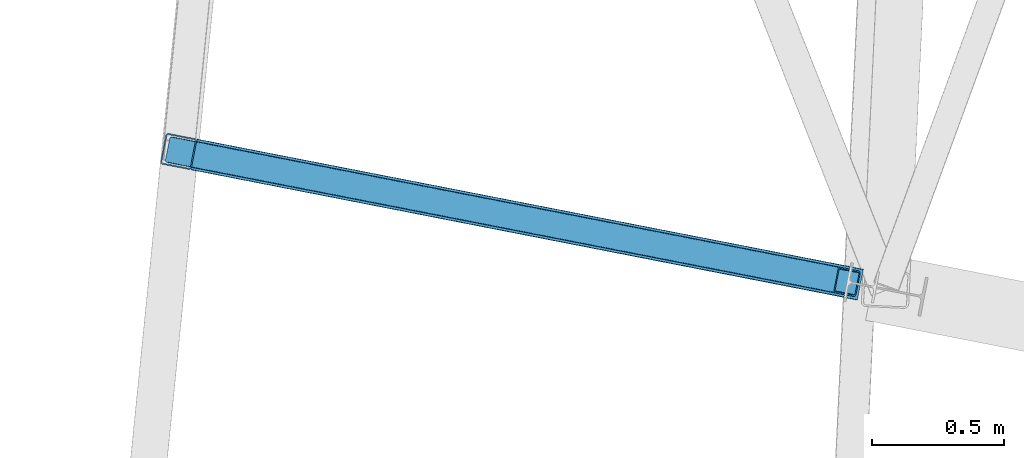
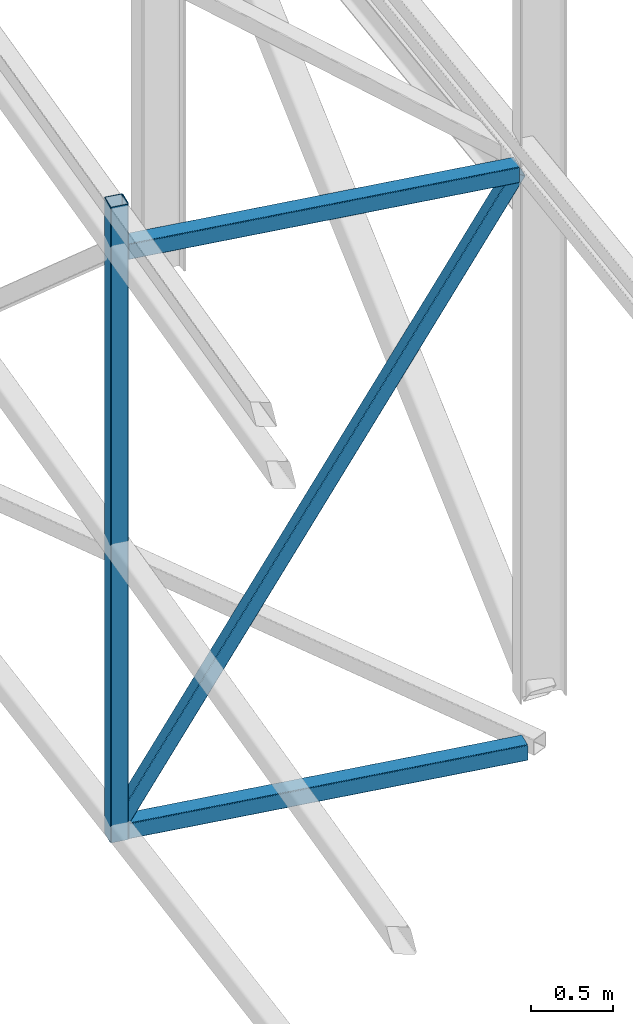
# One storey, part 41 of 215: 3 beams, 1 member, 4 elements without a shape of their own.
"""IFC2X3 building model written with IfcOpenShell, lengths in millimetres."""

import ifcopenshell
import ifcopenshell.guid

model = None  # the IFC model being written
_history = None  # IfcOwnerHistory: only IFC2X3 demands one
_inside = {}  # id of a spatial element -> (the spatial element, [elements in it])
_under = {}  # id of a project, library or spatial element -> (it, [spatial elements below it])
_declared = {}  # id of a project -> (the project, [libraries it declares])
_typed = {}  # id of a type object -> (the type object, [elements of that type])
_made_of = {}  # id of a material, layer set ... -> (it, [elements and type objects made of it])


def new_model(schema):
    """Start an empty IFC model of exactly this schema.

    Asked for "IFC4X3", IfcOpenShell would pick the latest addendum, in which some entities
    have other attributes; the version numbers below select the first issue.
    IFC2X3 requires an IfcOwnerHistory on every rooted entity: one is made here for all.
    """
    global model, _history
    if schema == "IFC4X3":
        model = ifcopenshell.file(schema_version=(4, 3, 0, 0))
    else:
        model = ifcopenshell.file(schema=schema)
    _inside.clear()
    _under.clear()
    _declared.clear()
    _typed.clear()
    _made_of.clear()
    _history = None
    if model.schema == "IFC2X3":
        org = make("IfcOrganization", Name="unknown")
        user = make(
            "IfcPersonAndOrganization",
            ThePerson=make("IfcPerson", FamilyName="unknown"),
            TheOrganization=org,
        )
        app = make(
            "IfcApplication",
            ApplicationDeveloper=org,
            Version="unknown",
            ApplicationFullName="unknown",
            ApplicationIdentifier="unknown",
        )
        _history = make(
            "IfcOwnerHistory",
            OwningUser=user,
            OwningApplication=app,
            ChangeAction="ADDED",
            CreationDate=0,
        )
    return model


def make(cls, **values):
    """One entity of the class cls with the attributes given. An attribute that is None is left unset."""
    return model.create_entity(
        cls, **{name: value for name, value in values.items() if value is not None}
    )


def rooted(cls, **values):
    """An entity with a GlobalId (a new one), such as an element, a storey or a relation."""
    return make(cls, GlobalId=ifcopenshell.guid.new(), OwnerHistory=_history, **values)


def si_unit(unit_type, name, prefix=None):
    """IfcSIUnit, for example si_unit("LENGTHUNIT", "METRE", prefix="MILLI")."""
    return make("IfcSIUnit", UnitType=unit_type, Prefix=prefix, Name=name)


def assignment(units):
    """IfcUnitAssignment: the units of a project."""
    return None if units is None else make("IfcUnitAssignment", Units=units)


def point(xyz):
    """IfcCartesianPoint."""
    return None if xyz is None else make("IfcCartesianPoint", Coordinates=xyz)


def direction(xyz):
    """IfcDirection."""
    return None if xyz is None else make("IfcDirection", DirectionRatios=xyz)


def frame(location, z_axis=None, x_axis=None):
    """IfcAxis2Placement3D, a coordinate frame: its origin and axes. An axis left out is left unset."""
    return make(
        "IfcAxis2Placement3D",
        Location=point(location),
        Axis=direction(z_axis),
        RefDirection=direction(x_axis),
    )


def frame_2d(location, x_axis=None):
    """IfcAxis2Placement2D, a coordinate frame in the plane: its origin and x axis."""
    return make(
        "IfcAxis2Placement2D", Location=point(location), RefDirection=direction(x_axis)
    )


def origin_with_axes():
    """The frame at (0, 0, 0) with the z axis (0, 0, 1) and the x axis (1, 0, 0) written out."""
    return frame((0.0, 0.0, 0.0), z_axis=(0.0, 0.0, 1.0), x_axis=(1.0, 0.0, 0.0))


def origin_2d_with_axis():
    """The frame at (0, 0) in the plane with the x axis (1, 0) written out."""
    return frame_2d((0.0, 0.0), x_axis=(1.0, 0.0))


def place(relative_to, where):
    """IfcLocalPlacement: puts the frame where relative to a parent placement (None: the world)."""
    return make(
        "IfcLocalPlacement", PlacementRelTo=relative_to, RelativePlacement=where
    )


def context(
    kind, dimensions, precision=None, world=None, true_north=None, identifier=None
):
    """IfcGeometricRepresentationContext, for example the 3D "Model" context."""
    return make(
        "IfcGeometricRepresentationContext",
        ContextIdentifier=identifier,
        ContextType=kind,
        CoordinateSpaceDimension=dimensions,
        Precision=precision,
        WorldCoordinateSystem=world,
        TrueNorth=true_north,
    )


def subcontext(parent, identifier, kind, view, scale=None):
    """IfcGeometricRepresentationSubContext, for example "Body" below "Model"."""
    return make(
        "IfcGeometricRepresentationSubContext",
        ContextIdentifier=identifier,
        ContextType=kind,
        ParentContext=parent,
        TargetScale=scale,
        TargetView=view,
    )


def project(units=None, contexts=None):
    """IfcProject with its units and contexts."""
    return rooted(
        "IfcProject",
        Name="project",
        RepresentationContexts=contexts,
        UnitsInContext=assignment(units),
    )


def spatial(cls, under=None, at=None, **own):
    """A site, building, storey or space (cls), placed at a placement, below another one or the project."""
    s = rooted(cls, ObjectPlacement=at, **own)
    if under is not None:
        _under.setdefault(under.id(), (under, []))[1].append(s)
    return s


def profile(cls, at=None, kind="AREA", **sizes):
    """A parametric profile (cls). Its sizes go by their IFC names, for example OverallWidth=200.0."""
    return make(cls, ProfileType=kind, Position=at, **sizes)


def hollow_rectangle(**sizes):
    """IfcRectangleHollowProfileDef."""
    return profile("IfcRectangleHollowProfileDef", **sizes)


def extrude(swept, where, along, depth):
    """IfcExtrudedAreaSolid: the profile swept, set in the frame where, extruded along a direction by depth."""
    return make(
        "IfcExtrudedAreaSolid",
        SweptArea=swept,
        Position=where,
        ExtrudedDirection=direction(along),
        Depth=depth,
    )


def shape(context_of_items, identifier, shape_type, items):
    """IfcShapeRepresentation: the items that make up one representation, for example the "Body"."""
    return make(
        "IfcShapeRepresentation",
        ContextOfItems=context_of_items,
        RepresentationIdentifier=identifier,
        RepresentationType=shape_type,
        Items=items,
    )


def material(Name=None, Category=None):
    """IfcMaterial."""
    return make("IfcMaterial", Name=Name, Category=Category)


def made_of(thing, what):
    """Note that an element or type object is made of a material, layer set ...; save() writes the relation."""
    if what is not None:
        _made_of.setdefault(what.id(), (what, []))[1].append(thing)
    return thing


def type_object(cls, material=None, **own):
    """A type object (cls), such as IfcWallType, which elements share."""
    return made_of(rooted(cls, **own), material)


def element(
    cls,
    number,
    at=None,
    inside=None,
    cuts=None,
    type_object=None,
    material=None,
    context=None,
    identifier="Body",
    shape_type=None,
    held_by="IfcProductDefinitionShape",
    body=None,
    shapes=None,
    **own,
):
    """One element of the class cls, such as IfcWall. Its Tag is "e" and its number.

    at: its placement. inside: the storey or other place that contains it. cuts: it is an
    opening in that element (IfcRelVoidsElement). A single representation is given by context,
    identifier, shape_type and body (its items); several are given by shapes. held_by: the class
    of the entity that holds the representations. save() writes the other relations.
    """
    e = rooted(cls, Tag="e%d" % number, ObjectPlacement=at, **own)
    if body is not None:
        shapes = [shape(context, identifier, shape_type, body)]
    if shapes is not None:
        e.Representation = make(held_by, Representations=shapes)
    if inside is not None:
        _inside.setdefault(inside.id(), (inside, []))[1].append(e)
    if cuts is not None:
        rooted(
            "IfcRelVoidsElement", RelatingBuildingElement=cuts, RelatedOpeningElement=e
        )
    if type_object is not None:
        _typed.setdefault(type_object.id(), (type_object, []))[1].append(e)
    return made_of(e, material)


def aggregate(whole, parts):
    """IfcRelAggregates: a whole, such as a stair, and the parts it consists of."""
    return rooted("IfcRelAggregates", RelatingObject=whole, RelatedObjects=parts)


def save(model, path):
    """Write the relations noted so far, then the file.

    IfcRelAggregates (storeys below a building ...), IfcRelContainedInSpatialStructure (elements
    in a storey), IfcRelDefinesByType, IfcRelAssociatesMaterial and IfcRelDeclares: one each for
    every whole, place, type object, material and project.
    """
    for whole, parts in _under.values():
        aggregate(whole, parts)
    for where, things in _inside.values():
        rooted(
            "IfcRelContainedInSpatialStructure",
            RelatedElements=things,
            RelatingStructure=where,
        )
    for kind, things in _typed.values():
        rooted("IfcRelDefinesByType", RelatedObjects=things, RelatingType=kind)
    for what, things in _made_of.values():
        rooted("IfcRelAssociatesMaterial", RelatedObjects=things, RelatingMaterial=what)
    for by, libraries in _declared.values():
        rooted("IfcRelDeclares", RelatingContext=by, RelatedDefinitions=libraries)
    model.write(path)


model = new_model("IFC2X3")

# Units and contexts
model_context = context("Model", 3, precision=1e-05, world=origin_with_axes())
body_context = subcontext(model_context, "Body", "Model", "MODEL_VIEW")
ifc_project = project(units=[si_unit("LENGTHUNIT", "METRE", prefix="MILLI"), si_unit("AREAUNIT", "SQUARE_METRE"), si_unit("VOLUMEUNIT", "CUBIC_METRE"), si_unit("MASSUNIT", "GRAM", prefix="KILO"), si_unit("TIMEUNIT", "SECOND"), si_unit("PLANEANGLEUNIT", "RADIAN"), si_unit("SOLIDANGLEUNIT", "STERADIAN"), si_unit("THERMODYNAMICTEMPERATUREUNIT", "DEGREE_CELSIUS"), si_unit("LUMINOUSINTENSITYUNIT", "LUMEN")], contexts=[model_context])

# Site, building, storey
site_placement = place(None, origin_with_axes())
site = spatial("IfcSite", under=ifc_project, at=site_placement, CompositionType="ELEMENT")
building_placement = place(site_placement, origin_with_axes())
building = spatial("IfcBuilding", under=site, at=building_placement, Name="Undefined", CompositionType="ELEMENT")
storey_placement = place(building_placement, origin_with_axes())
storey = spatial("IfcBuildingStorey", under=building, at=storey_placement, Name="Undefined", CompositionType="ELEMENT", Elevation=0.0)

# Assembly, beam
assembly_1_placement = place(storey_placement, origin_with_axes())
assembly_1 = element("IfcElementAssembly", 1, at=assembly_1_placement, inside=storey, Name="Steel Assembly", AssemblyPlace="NOTDEFINED", PredefinedType="RIGID_FRAME")
ifc_material = material(Name="STEEL/S275JR")
beam_type = type_object("IfcBeamType", PredefinedType="NOTDEFINED")
beam_1_placement = place(assembly_1_placement, frame((35013.7869480497, 24593.9605630966, 4307.72239913105), z_axis=(-0.981422412140383, 0.191859451027444, 0.0), x_axis=(0.0, 0.0, -1.0)))
beam_1 = element("IfcBeam", 2, at=beam_1_placement, type_object=beam_type, material=ifc_material, Name="MONTANT", context=body_context, shape_type="SweptSolid", body=[
    extrude(hollow_rectangle(XDim=120.0, YDim=120.0, WallThickness=5.0, InnerFilletRadius=5.0, OuterFilletRadius=10.0, at=origin_2d_with_axis()), frame((4750.9809063844, 0.0, 0.0), z_axis=(-1.0, 0.0, 0.0), x_axis=(-6.93889390390723e-18, -1.0, -3.46944695195361e-18)), (0.0, 0.0, 1.0), 4751.0),
])
aggregate(assembly_1, [beam_1])

assembly_2_placement = place(storey_placement, origin_with_axes())
assembly_2 = element("IfcElementAssembly", 3, at=assembly_2_placement, inside=storey, Name="Steel Assembly", AssemblyPlace="NOTDEFINED", PredefinedType="RIGID_FRAME")
beam_2_placement = place(assembly_2_placement, frame((35072.6775036594, 24582.475648575, -383.258507641311), z_axis=(0.0, 0.0, 1.0), x_axis=(0.981422409205525, -0.19185946604018, 1.89999991602007e-08)))
beam_2 = element("IfcBeam", 4, at=beam_2_placement, type_object=beam_type, material=ifc_material, Name="POUTRE", context=body_context, shape_type="SweptSolid", body=[
    extrude(hollow_rectangle(XDim=120.0, YDim=120.0, WallThickness=5.0, InnerFilletRadius=5.0, OuterFilletRadius=10.0, at=origin_2d_with_axis()), frame((2581.32730617493, 0.0, 0.0), z_axis=(-1.0, 0.0, 0.0), x_axis=(-6.93889390390723e-18, -1.0, -3.46944695195361e-18)), (0.0, 0.0, 1.0), 2581.3),
])
aggregate(assembly_2, [beam_2])

assembly_3_placement = place(storey_placement, origin_with_axes())
assembly_3 = element("IfcElementAssembly", 5, at=assembly_3_placement, inside=storey, Name="Steel Assembly", AssemblyPlace="NOTDEFINED", PredefinedType="RIGID_FRAME")
beam_3_placement = place(assembly_3_placement, frame((35072.6911574716, 24582.4623526113, 3947.43266548086), z_axis=(0.0, 0.0, 1.0), x_axis=(0.981482571300331, -0.191551461058614, 0.0)))
beam_3 = element("IfcBeam", 6, at=beam_3_placement, type_object=beam_type, material=ifc_material, Name="POUTRE", context=body_context, shape_type="SweptSolid", body=[
    extrude(hollow_rectangle(XDim=120.0, YDim=120.0, WallThickness=5.0, InnerFilletRadius=5.0, OuterFilletRadius=10.0, at=origin_2d_with_axis()), frame((2529.36312252823, 0.0, 4.54747350886464e-13), z_axis=(-1.0, 0.0, 0.0), x_axis=(-6.93889390390723e-18, -1.0, -3.46944695195361e-18)), (0.0, 0.0, 1.0), 2529.4),
])
aggregate(assembly_3, [beam_3])

# Assembly, member
assembly_4_placement = place(storey_placement, origin_with_axes())
assembly_4 = element("IfcElementAssembly", 7, at=assembly_4_placement, inside=storey, Name="Steel Assembly", AssemblyPlace="NOTDEFINED", PredefinedType="RIGID_FRAME")
member_type = type_object("IfcMemberType", PredefinedType="NOTDEFINED")
member_placement = place(assembly_4_placement, frame((35013.7901565404, 24593.9769730854, -353.258507740693), z_axis=(-0.840838551488371, 0.164109781095316, 0.515808598299588), x_axis=(0.506256430987998, -0.0988075709976577, 0.856703851979689)))
member = element("IfcMember", 8, at=member_placement, type_object=member_type, material=ifc_material, Name="POUTRE", context=body_context, shape_type="SweptSolid", body=[
    extrude(hollow_rectangle(XDim=100.0, YDim=100.0, WallThickness=5.0, InnerFilletRadius=5.0, OuterFilletRadius=10.0, at=origin_2d_with_axis()), frame((5020.04416491045, -8.44403806034256e-14, -3.63797880709171e-12), z_axis=(-1.0, 0.0, 0.0), x_axis=(-6.93889390390723e-18, -1.0, -3.46944695195361e-18)), (0.0, 0.0, 1.0), 5020.0),
])
aggregate(assembly_4, [member])

save(model, "model.ifc")
